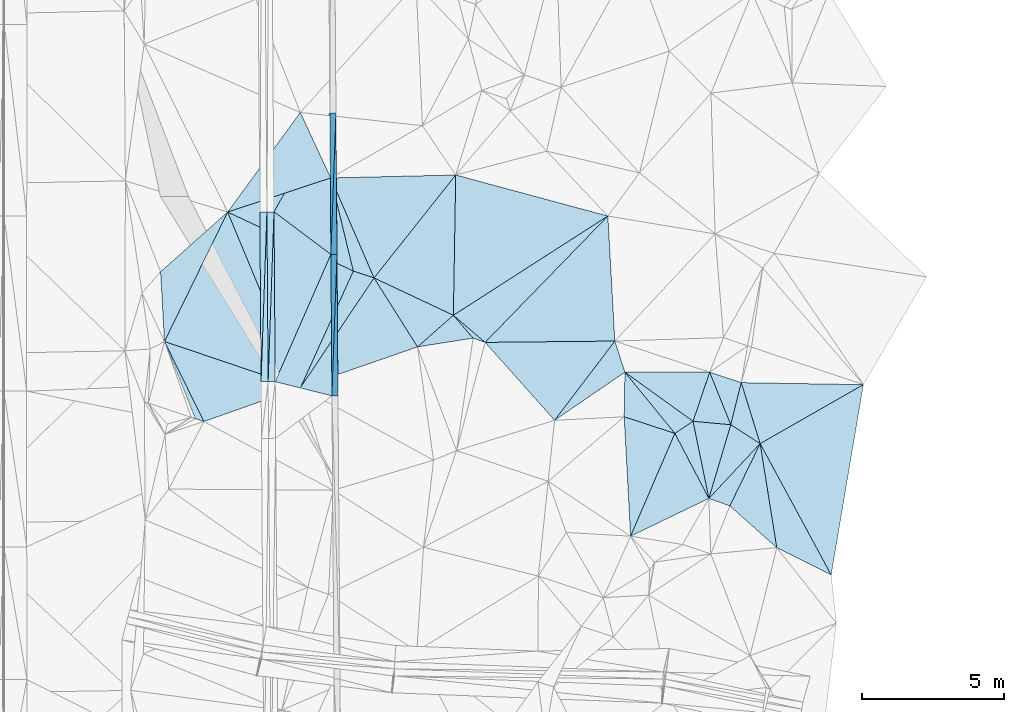
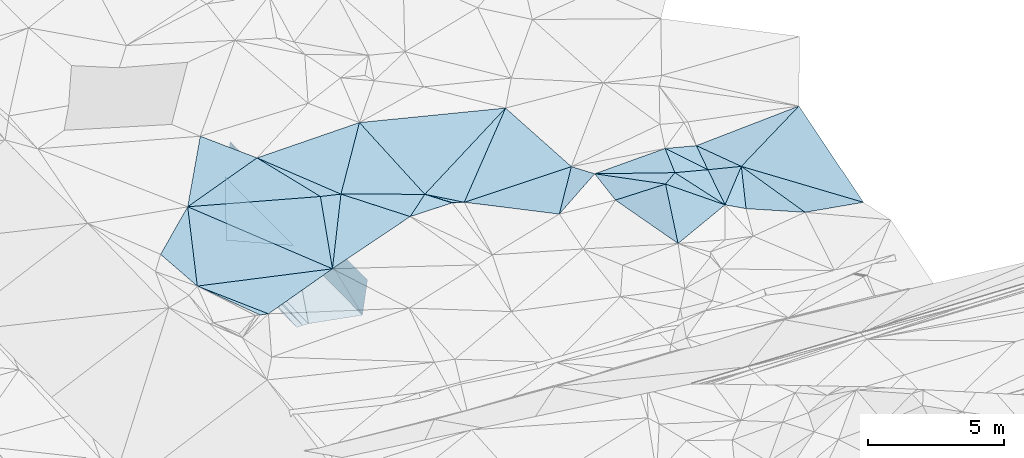
# One storey, part 118 of 275: 47 plates.
"""IFC2X3 building model written with IfcOpenShell, lengths in millimetres."""

from ifc_helpers import new_model, si_unit, frame, origin_with_axes, place, context, subcontext, project, spatial, polyline, outline, extrude, material, type_object, element, save


model = new_model("IFC2X3")

# Units and contexts
model_context = context("Model", 3, precision=1e-05, world=origin_with_axes())
body_context = subcontext(model_context, "Body", "Model", "MODEL_VIEW")
ifc_project = project(units=[si_unit("LENGTHUNIT", "METRE", prefix="MILLI"), si_unit("AREAUNIT", "SQUARE_METRE"), si_unit("VOLUMEUNIT", "CUBIC_METRE"), si_unit("MASSUNIT", "GRAM", prefix="KILO"), si_unit("TIMEUNIT", "SECOND"), si_unit("PLANEANGLEUNIT", "RADIAN"), si_unit("SOLIDANGLEUNIT", "STERADIAN"), si_unit("THERMODYNAMICTEMPERATUREUNIT", "DEGREE_CELSIUS"), si_unit("LUMINOUSINTENSITYUNIT", "LUMEN")], contexts=[model_context])

# Site, building, storey
site_placement = place(None, origin_with_axes())
site = spatial("IfcSite", under=ifc_project, at=site_placement, CompositionType="ELEMENT")
building_placement = place(site_placement, origin_with_axes())
building = spatial("IfcBuilding", under=site, at=building_placement, Name="Undefined", CompositionType="ELEMENT")
storey_placement = place(building_placement, origin_with_axes())
storey = spatial("IfcBuildingStorey", under=building, at=storey_placement, Name="Undefined", CompositionType="ELEMENT", Elevation=0.0)

# Plates
ifc_material = material()
plate_type_1 = type_object("IfcPlateType", PredefinedType="NOTDEFINED")
for number, where, z_axis, x_axis, name in (
    (1, (-45683.2373323279, 92966.7539989016, 44689.9872892128), (0.989902789621391, 0.00962387440535802, -0.141420819334417), (0.00717851400324311, -0.999815950858989, -0.0177913840001465), "00_PR"),
    (2, (-45861.6191404362, 87965.3449309683, 43101.0162901396), (0.989902789621391, 0.00962387440535802, -0.141420819334417), (-0.00717851400874594, 0.999815950858389, 0.0177913840316381), "00_PR"),
):
    element("IfcPlate", number, at=place(storey_placement, frame(where, z_axis=z_axis, x_axis=x_axis)), inside=storey, type_object=plate_type_1, material=ifc_material, Name=name, context=body_context, shape_type="SweptSolid", body=[
        extrude(outline(polyline([(0.0, 0.0), (5000.79150390625, -2.90528987534344e-08), (5027.47802734375, 1514.99377441406), (0.0, 0.0)])), frame((-8.85201319254618e-08, 2.18876761149539e-07, -0.5000001331573), z_axis=(0.0, 0.0, 1.0), x_axis=(1.0, 0.0, 0.0)), (0.0, 0.0, 1.0), 1.0),
    ])
plate_type_2 = type_object("IfcPlateType", PredefinedType="NOTDEFINED")
for number, where, z_axis, x_axis, name in (
    (3, (-45647.3390831942, 87966.8832514009, 44601.0162893921), (0.989898743353492, 0.0100336620146458, -0.14142066162253), (0.00717811400295095, -0.999760220774989, -0.0206875720012088), "00_PR"),
    (4, (-45825.7208917651, 82965.4741815334, 42997.5562900723), (0.989898743353492, 0.0100336620146458, -0.14142066162253), (-0.00717811401574965, 0.99976022077431, 0.0206875720296029), "00_PR"),
):
    element("IfcPlate", number, at=place(storey_placement, frame(where, z_axis=z_axis, x_axis=x_axis)), inside=storey, type_object=plate_type_2, material=ifc_material, Name=name, context=body_context, shape_type="SweptSolid", body=[
        extrude(outline(polyline([(0.0, 0.0), (5001.0703125, -2.76850187219679e-08), (5032.10107421875, 1514.91101074219), (0.0, 0.0)])), frame((-8.85201319254618e-08, 2.18876761149539e-07, -0.5000001331573), z_axis=(0.0, 0.0, 1.0), x_axis=(1.0, 0.0, 0.0)), (0.0, 0.0, 1.0), 1.0),
    ])
plate_type_3 = type_object("IfcPlateType", PredefinedType="NOTDEFINED")
plate_1_placement = place(storey_placement, frame((-48079.9031369125, 83467.4698453673, 43019.8517308433), z_axis=(-0.0500743211191804, 0.0203698148144253, -0.998537747413126), x_axis=(0.0344500070027547, 0.99923227325048, 0.0186563960128271)))
element("IfcPlate", 5, at=plate_1_placement, inside=storey, type_object=plate_type_3, material=ifc_material, Name="00_PR", context=body_context, shape_type="SweptSolid", body=[
    extrude(outline(polyline([(0.0, 0.0), (6006.2509765625, -4.09854692406952e-08), (10.1724472045898, 250.105972290039), (0.0, 0.0)])), frame((-8.85201319254618e-08, 2.18876761149539e-07, -0.5000001331573), z_axis=(0.0, 0.0, 1.0), x_axis=(1.0, 0.0, 0.0)), (0.0, 0.0, 1.0), 1.0),
])
plate_2_placement = place(storey_placement, frame((-48079.9031369125, 83467.4698453673, 43019.8517308433), z_axis=(-0.0500743211191804, 0.0203698148144253, -0.998537747413126), x_axis=(-0.00717807001013827, 0.999758829912239, 0.0207546940097849)))
element("IfcPlate", 6, at=plate_2_placement, inside=storey, type_object=plate_type_3, material=ifc_material, Name="00_PR", context=body_context, shape_type="SweptSolid", body=[
    extrude(outline(polyline([(0.0, 0.0), (6001.29296875, 1.02445483207703e-08), (6001.033203125, 250.311706542969), (0.0, 0.0)])), frame((-8.85201319254618e-08, 2.18876761149539e-07, -0.5000001331573), z_axis=(0.0, 0.0, 1.0), x_axis=(1.0, 0.0, 0.0)), (0.0, 0.0, 1.0), 1.0),
])
for number, where, z_axis, x_axis, name in (
    (7, (-48122.9458806108, 89467.3157739402, 43144.4062080535), (0.0198421780331149, 0.0208935438694051, -0.999584787697111), (0.00717807002162699, -0.999758829911683, -0.0207546940325866), "00_PR"),
    (8, (-48329.8621855433, 83465.6753719548, 43014.851207862), (0.0198421780331149, 0.0208935438694051, -0.999584787697111), (-0.00717807001013827, 0.999758829912239, 0.0207546940097849), "00_PR"),
):
    element("IfcPlate", number, at=place(storey_placement, frame(where, z_axis=z_axis, x_axis=x_axis)), inside=storey, type_object=plate_type_3, material=ifc_material, Name=name, context=body_context, shape_type="SweptSolid", body=[
        extrude(outline(polyline([(0.0, 0.0), (6001.29296875, 1.02445483207703e-08), (6001.396484375, 250.050430297852), (0.0, 0.0)])), frame((-8.85201319254618e-08, 2.18876761149539e-07, -0.5000001331573), z_axis=(0.0, 0.0, 1.0), x_axis=(1.0, 0.0, 0.0)), (0.0, 0.0, 1.0), 1.0),
    ])
plate_type_4 = type_object("IfcPlateType", PredefinedType="NOTDEFINED")
plate_3_placement = place(storey_placement, frame((-45898.0134832116, 92965.2199599248, 43189.5580809568), z_axis=(-0.00227963076145979, 0.0177754340244716, -0.999839405719155), x_axis=(0.00717851400324311, -0.999815950858989, -0.0177913840001465)))
element("IfcPlate", 9, at=plate_3_placement, inside=storey, type_object=plate_type_4, material=ifc_material, Name="00_PR", context=body_context, shape_type="SweptSolid", body=[
    extrude(outline(polyline([(0.0, 0.0), (5000.79150390625, -2.90528987534344e-08), (3482.31640625, 2000.00500488281), (0.0, 0.0)])), frame((-8.85201319254618e-08, 2.18876761149539e-07, -0.5000001331573), z_axis=(0.0, 0.0, 1.0), x_axis=(1.0, 0.0, 0.0)), (0.0, 0.0, 1.0), 1.0),
])
plate_4_placement = place(storey_placement, frame((-45862.1140412533, 87965.3504638584, 43100.5871074765), z_axis=(0.000100272310363569, 0.0206888245440917, -0.999785958335307), x_axis=(0.00717811400295095, -0.999760220774989, -0.0206875720012088)))
element("IfcPlate", 10, at=plate_4_placement, inside=storey, type_object=plate_type_4, material=ifc_material, Name="00_PR", context=body_context, shape_type="SweptSolid", body=[
    extrude(outline(polyline([(0.0, 0.0), (5001.0703125, -2.76850187219679e-08), (4482.8115234375, 1999.99963378906), (0.0, 0.0)])), frame((-8.85201319254618e-08, 2.18876761149539e-07, -0.5000001331573), z_axis=(0.0, 0.0, 1.0), x_axis=(1.0, 0.0, 0.0)), (0.0, 0.0, 1.0), 1.0),
])
plate_5_placement = place(storey_placement, frame((-47872.9627324766, 89469.1100334616, 43131.9061082618), z_axis=(-5.06882224549782e-05, 0.0207548664900474, -0.999784593273813), x_axis=(0.800773641961817, -0.598837224948012, -0.0124720630118285)))
element("IfcPlate", 11, at=plate_5_placement, inside=storey, type_object=plate_type_4, material=ifc_material, Name="00_PR", context=body_context, shape_type="SweptSolid", body=[
    extrude(outline(polyline([(0.0, 0.0), (2511.13232421875, 3.71801434084773e-09), (3628.98046875, 4779.75048828125), (0.0, 0.0)])), frame((-8.85201319254618e-08, 2.18876761149539e-07, -0.5000001331573), z_axis=(0.0, 0.0, 1.0), x_axis=(1.0, 0.0, 0.0)), (0.0, 0.0, 1.0), 1.0),
])
plate_type_5 = type_object("IfcPlateType", PredefinedType="NOTDEFINED")
plate_6_placement = place(storey_placement, frame((-45069.3131982362, 87377.9734556532, 45389.5001155122), z_axis=(0.00706609497051216, 0.0210894659351489, -0.999752621766224), x_axis=(0.948192909023164, -0.31769514833908, 1.36898628105037e-10)))
element("IfcPlate", 12, at=plate_6_placement, inside=storey, type_object=plate_type_5, material=ifc_material, Name="00", context=body_context, shape_type="SweptSolid", body=[
    extrude(outline(polyline([(0.0, 0.0), (771.556884765625, -1.94995664060116e-09), (-461.015930175781, 4496.0498046875), (0.0, 0.0)])), frame((-8.85201319254618e-08, 2.18876761149539e-07, -0.5000001331573), z_axis=(0.0, 0.0, 1.0), x_axis=(1.0, 0.0, 0.0)), (0.0, 0.0, 1.0), 1.0),
])
plate_type_6 = type_object("IfcPlateType", PredefinedType="NOTDEFINED")
plate_7_placement = place(storey_placement, frame((-37959.0404684161, 82102.4163246774, 45309.502815184), z_axis=(-0.00542668028163946, -0.105954084567651, -0.99435621539997), x_axis=(-0.663259744439591, 0.744549252573234, -0.0757160610344114)))
element("IfcPlate", 13, at=plate_7_placement, inside=storey, type_object=plate_type_6, material=ifc_material, Name="00", context=body_context, shape_type="SweptSolid", body=[
    extrude(outline(polyline([(0.0, 0.0), (3698.02661132813, 1.55523594003171e-08), (695.884704589844, 3462.40454101563), (0.0, 0.0)])), frame((-8.85201319254618e-08, 2.18876761149539e-07, -0.5000001331573), z_axis=(0.0, 0.0, 1.0), x_axis=(1.0, 0.0, 0.0)), (0.0, 0.0, 1.0), 1.0),
])
plate_type_7 = type_object("IfcPlateType", PredefinedType="NOTDEFINED")
plate_8_placement = place(storey_placement, frame((-32479.007107718, 83803.5718765029, 45309.5097408913), z_axis=(-0.194021096222563, -0.030273157857917, -0.980530137289979), x_axis=(0.371728776040568, -0.927253620632982, -0.0449270529459386)))
element("IfcPlate", 14, at=plate_8_placement, inside=storey, type_object=plate_type_7, material=ifc_material, Name="00", context=body_context, shape_type="SweptSolid", body=[
    extrude(outline(polyline([(0.0, 0.0), (2003.24731445313, -1.27402017824352e-08), (1383.50366210938, 1214.4619140625), (0.0, 0.0)])), frame((-8.85201319254618e-08, 2.18876761149539e-07, -0.5000001331573), z_axis=(0.0, 0.0, 1.0), x_axis=(1.0, 0.0, 0.0)), (0.0, 0.0, 1.0), 1.0),
])
plate_type_8 = type_object("IfcPlateType", PredefinedType="NOTDEFINED")
plate_9_placement = place(storey_placement, frame((-35829.3912940867, 84902.594573461, 44999.5089668839), z_axis=(0.080892518904308, -0.170241806279899, -0.982076436831611), x_axis=(0.301823274072309, -0.934860647811207, 0.186917843991104)))
element("IfcPlate", 15, at=plate_9_placement, inside=storey, type_object=plate_type_8, material=ifc_material, Name="00", context=body_context, shape_type="SweptSolid", body=[
    extrude(outline(polyline([(0.0, 0.0), (1176.98767089844, 2.25554686039686e-10), (2032.98645019531, 2887.8134765625), (0.0, 0.0)])), frame((-8.85201319254618e-08, 2.18876761149539e-07, -0.5000001331573), z_axis=(0.0, 0.0, 1.0), x_axis=(1.0, 0.0, 0.0)), (0.0, 0.0, 1.0), 1.0),
])
plate_type_9 = type_object("IfcPlateType", PredefinedType="NOTDEFINED")
plate_10_placement = place(storey_placement, frame((-31734.1971798722, 81946.0032001781, 45219.5066586934), z_axis=(0.0964550703391548, -0.130885011541234, -0.986694245022094), x_axis=(0.831550725592776, -0.534203576559555, 0.152151009057148)))
element("IfcPlate", 16, at=plate_10_placement, inside=storey, type_object=plate_type_9, material=ifc_material, Name="00", context=body_context, shape_type="SweptSolid", body=[
    extrude(outline(polyline([(0.0, 0.0), (1248.75939941406, -2.51020537689328e-09), (790.064147949219, 2613.65625), (0.0, 0.0)])), frame((-8.85201319254618e-08, 2.18876761149539e-07, -0.5000001331573), z_axis=(0.0, 0.0, 1.0), x_axis=(1.0, 0.0, 0.0)), (0.0, 0.0, 1.0), 1.0),
])
plate_type_10 = type_object("IfcPlateType", PredefinedType="NOTDEFINED")
plate_11_placement = place(storey_placement, frame((-32507.0603143822, 79341.1652521589, 45489.5101011329), z_axis=(-0.195102063017076, -0.0436833121646322, -0.979809651536873), x_axis=(-0.201272626133684, 0.979528672924914, -0.00359289398764216)))
element("IfcPlate", 17, at=plate_11_placement, inside=storey, type_object=plate_type_10, material=ifc_material, Name="00", context=body_context, shape_type="SweptSolid", body=[
    extrude(outline(polyline([(0.0, 0.0), (2783.271484375, -2.91038304567337e-09), (2396.99951171875, 1307.5908203125), (0.0, 0.0)])), frame((-8.85201319254618e-08, 2.18876761149539e-07, -0.5000001331573), z_axis=(0.0, 0.0, 1.0), x_axis=(1.0, 0.0, 0.0)), (0.0, 0.0, 1.0), 1.0),
])
plate_type_11 = type_object("IfcPlateType", PredefinedType="NOTDEFINED")
plate_12_placement = place(storey_placement, frame((-49510.4156340631, 89460.0204792745, 45219.5000540307), z_axis=(0.0149171128117454, -0.00509312745644573, -0.999875762181519), x_axis=(0.383781072661369, -0.923365216938025, 0.0104290179730582)))
element("IfcPlate", 18, at=plate_12_placement, inside=storey, type_object=plate_type_11, material=ifc_material, Name="00", context=body_context, shape_type="SweptSolid", body=[
    extrude(outline(polyline([(0.0, 0.0), (6712.04150390625, -3.09519236907363e-08), (3365.83154296875, 3815.98999023438), (0.0, 0.0)])), frame((-8.85201319254618e-08, 2.18876761149539e-07, -0.5000001331573), z_axis=(0.0, 0.0, 1.0), x_axis=(1.0, 0.0, 0.0)), (0.0, 0.0, 1.0), 1.0),
])
plate_type_12 = type_object("IfcPlateType", PredefinedType="NOTDEFINED")
plate_13_placement = place(storey_placement, frame((-35499.4782809632, 82227.6693787612, 44999.5244804639), z_axis=(0.281136504555404, 0.128325812423264, -0.951049289822709), x_axis=(0.0159907927948712, 0.99025528956161, 0.138342892990725)))
element("IfcPlate", 19, at=plate_13_placement, inside=storey, type_object=plate_type_12, material=ifc_material, Name="00", context=body_context, shape_type="SweptSolid", body=[
    extrude(outline(polyline([(0.0, 0.0), (1590.25158691406, 3.66708263754845e-09), (-489.733825683594, 1873.56896972656), (0.0, 0.0)])), frame((-8.85201319254618e-08, 2.18876761149539e-07, -0.5000001331573), z_axis=(0.0, 0.0, 1.0), x_axis=(1.0, 0.0, 0.0)), (0.0, 0.0, 1.0), 1.0),
])
plate_type_13 = type_object("IfcPlateType", PredefinedType="NOTDEFINED")
plate_14_placement = place(storey_placement, frame((-51741.9884825936, 84887.2114247014, 45209.5000925709), z_axis=(0.0189288990313736, -0.0070510934098167, -0.99979596861719), x_axis=(-0.056036672613361, 0.998395836590678, -0.00810214791416807)))
element("IfcPlate", 20, at=plate_14_placement, inside=storey, type_object=plate_type_13, material=ifc_material, Name="00", context=body_context, shape_type="SweptSolid", body=[
    extrude(outline(polyline([(0.0, 0.0), (2468.48120117188, -1.78988557308912e-09), (4440.34130859375, 2484.7470703125), (0.0, 0.0)])), frame((-8.85201319254618e-08, 2.18876761149539e-07, -0.5000001331573), z_axis=(0.0, 0.0, 1.0), x_axis=(1.0, 0.0, 0.0)), (0.0, 0.0, 1.0), 1.0),
])
plate_type_14 = type_object("IfcPlateType", PredefinedType="NOTDEFINED")
plate_15_placement = place(storey_placement, frame((-41534.985015347, 85813.5055388297, 45199.5055283287), z_axis=(-0.139167559526725, 0.0515075948223284, -0.988928388737523), x_axis=(0.647270419543151, -0.751057556634857, -0.13020580096951)))
element("IfcPlate", 21, at=plate_15_placement, inside=storey, type_object=plate_type_14, material=ifc_material, Name="00", context=body_context, shape_type="SweptSolid", body=[
    extrude(outline(polyline([(0.0, 0.0), (1075.22094726563, 1.54614099301398e-09), (3.99917817115784, 1693.09887695313), (0.0, 0.0)])), frame((-8.85201319254618e-08, 2.18876761149539e-07, -0.5000001331573), z_axis=(0.0, 0.0, 1.0), x_axis=(1.0, 0.0, 0.0)), (0.0, 0.0, 1.0), 1.0),
])
plate_type_15 = type_object("IfcPlateType", PredefinedType="NOTDEFINED")
plate_16_placement = place(storey_placement, frame((-30695.9725358323, 81279.0826604952, 45409.5300178736), z_axis=(-0.267800766856373, 0.211489577245417, -0.93997601458106), x_axis=(-0.436350901048086, -0.896443284541261, -0.0773778311624195)))
element("IfcPlate", 22, at=plate_16_placement, inside=storey, type_object=plate_type_15, material=ifc_material, Name="00", context=body_context, shape_type="SweptSolid", body=[
    extrude(outline(polyline([(0.0, 0.0), (2455.48364257813, -1.29366526380181e-08), (2521.21411132813, 827.6953125), (0.0, 0.0)])), frame((-8.85201319254618e-08, 2.18876761149539e-07, -0.5000001331573), z_axis=(0.0, 0.0, 1.0), x_axis=(1.0, 0.0, 0.0)), (0.0, 0.0, 1.0), 1.0),
])
plate_type_16 = type_object("IfcPlateType", PredefinedType="NOTDEFINED")
plate_17_placement = place(storey_placement, frame((-40411.7964613095, 84855.9120419585, 45029.5064584402), z_axis=(-0.0131881662296389, 0.159755708752198, -0.987068480801906), x_axis=(-0.941389601389961, 0.330778724460133, 0.0661139458766262)))
element("IfcPlate", 23, at=plate_17_placement, inside=storey, type_object=plate_type_16, material=ifc_material, Name="00", context=body_context, shape_type="SweptSolid", body=[
    extrude(outline(polyline([(0.0, 0.0), (453.762054443359, -2.29556462727487e-09), (1385.3076171875, 536.957153320313), (0.0, 0.0)])), frame((-8.85201319254618e-08, 2.18876761149539e-07, -0.5000001331573), z_axis=(0.0, 0.0, 1.0), x_axis=(1.0, 0.0, 0.0)), (0.0, 0.0, 1.0), 1.0),
])
plate_type_17 = type_object("IfcPlateType", PredefinedType="NOTDEFINED")
plate_18_placement = place(storey_placement, frame((-36076.6303756705, 89319.933680033, 45039.5000354299), z_axis=(-0.00663523232918316, 0.00868355123193243, -0.999940283031912), x_axis=(0.0558716591705194, -0.998397025213092, -0.00904089305218204)))
element("IfcPlate", 24, at=plate_18_placement, inside=storey, type_object=plate_type_17, material=ifc_material, Name="00", context=body_context, shape_type="SweptSolid", body=[
    extrude(outline(polyline([(0.0, 0.0), (4424.341796875, 1.10994733404368e-08), (4214.81884765625, 4577.9033203125), (0.0, 0.0)])), frame((-8.85201319254618e-08, 2.18876761149539e-07, -0.5000001331573), z_axis=(0.0, 0.0, 1.0), x_axis=(1.0, 0.0, 0.0)), (0.0, 0.0, 1.0), 1.0),
])
plate_type_18 = type_object("IfcPlateType", PredefinedType="NOTDEFINED")
plate_19_placement = place(storey_placement, frame((-31734.2567949943, 81946.0882787953, 45219.5005214637), z_axis=(-0.0227761751673232, 0.0392709955451937, -0.998968985881762), x_axis=(-0.371728776044028, 0.927253620631453, 0.044927052948877)))
element("IfcPlate", 25, at=plate_19_placement, inside=storey, type_object=plate_type_18, material=ifc_material, Name="00", context=body_context, shape_type="SweptSolid", body=[
    extrude(outline(polyline([(0.0, 0.0), (2003.24731445313, -1.27402017824352e-08), (1243.13159179688, 897.119812011719), (0.0, 0.0)])), frame((-8.85201319254618e-08, 2.18876761149539e-07, -0.5000001331573), z_axis=(0.0, 0.0, 1.0), x_axis=(1.0, 0.0, 0.0)), (0.0, 0.0, 1.0), 1.0),
])
plate_type_19 = type_object("IfcPlateType", PredefinedType="NOTDEFINED")
plate_20_placement = place(storey_placement, frame((-28184.8235706216, 76637.9508991514, 45729.5013580698), z_axis=(0.0654896818174917, -0.0333314161094109, -0.997296404423271), x_axis=(-0.47498590190887, 0.877909013475588, -0.060532281025393)))
element("IfcPlate", 26, at=plate_20_placement, inside=storey, type_object=plate_type_19, material=ifc_material, Name="00", context=body_context, shape_type="SweptSolid", body=[
    extrude(outline(polyline([(0.0, 0.0), (5286.435546875, -2.04508978640661e-08), (5371.8994140625, 4204.6279296875), (0.0, 0.0)])), frame((-8.85201319254618e-08, 2.18876761149539e-07, -0.5000001331573), z_axis=(0.0, 0.0, 1.0), x_axis=(1.0, 0.0, 0.0)), (0.0, 0.0, 1.0), 1.0),
])
plate_type_20 = type_object("IfcPlateType", PredefinedType="NOTDEFINED")
plate_21_placement = place(storey_placement, frame((-33067.121228654, 82067.4592223667, 45479.5019323227), z_axis=(0.0757875477335134, -0.0441386339537898, -0.996146589915979), x_axis=(-0.832709603420894, -0.552343305842593, -0.0388791571602632)))
element("IfcPlate", 27, at=plate_21_placement, inside=storey, type_object=plate_type_20, material=ifc_material, Name="00", context=body_context, shape_type="SweptSolid", body=[
    extrude(outline(polyline([(0.0, 0.0), (771.621643066406, 7.13043846189976e-10), (1056.21704101563, 2784.888671875), (0.0, 0.0)])), frame((-8.85201319254618e-08, 2.18876761149539e-07, -0.5000001331573), z_axis=(0.0, 0.0, 1.0), x_axis=(1.0, 0.0, 0.0)), (0.0, 0.0, 1.0), 1.0),
])
plate_type_21 = type_object("IfcPlateType", PredefinedType="NOTDEFINED")
plate_22_placement = place(storey_placement, frame((-32478.8951458552, 83803.5332952813, 45309.5031248418), z_axis=(0.0299038375530636, -0.107441824182214, -0.993761548318307), x_axis=(-0.319540146810321, -0.943062301950931, 0.092344946886387)))
element("IfcPlate", 28, at=plate_22_placement, inside=storey, type_object=plate_type_21, material=ifc_material, Name="00", context=body_context, shape_type="SweptSolid", body=[
    extrude(outline(polyline([(0.0, 0.0), (1840.92370605469, -7.9890014603734e-09), (949.957885742188, 2842.0732421875), (0.0, 0.0)])), frame((-8.85201319254618e-08, 2.18876761149539e-07, -0.5000001331573), z_axis=(0.0, 0.0, 1.0), x_axis=(1.0, 0.0, 0.0)), (0.0, 0.0, 1.0), 1.0),
])
plate_type_22 = type_object("IfcPlateType", PredefinedType="NOTDEFINED")
plate_23_placement = place(storey_placement, frame((-32506.9411709979, 79341.1897008722, 45489.5004788604), z_axis=(0.0431898333453875, 0.00521009578161588, -0.999053298476885), x_axis=(-0.463323614112765, 0.886055184823519, -0.0154090250452651)))
element("IfcPlate", 29, at=plate_23_placement, inside=storey, type_object=plate_type_22, material=ifc_material, Name="00", context=body_context, shape_type="SweptSolid", body=[
    extrude(outline(polyline([(0.0, 0.0), (2595.88134765625, 1.35769369080663e-08), (2675.353515625, 767.518188476563), (0.0, 0.0)])), frame((-8.85201319254618e-08, 2.18876761149539e-07, -0.5000001331573), z_axis=(0.0, 0.0, 1.0), x_axis=(1.0, 0.0, 0.0)), (0.0, 0.0, 1.0), 1.0),
])
plate_type_23 = type_object("IfcPlateType", PredefinedType="NOTDEFINED")
plate_24_placement = place(storey_placement, frame((-33709.6983225532, 81641.271265789, 45449.5001106321), z_axis=(-0.00485471230257463, -0.019925493793915, -0.999789681115747), x_axis=(0.463323614101443, -0.886055184829428, 0.0154090250458884)))
element("IfcPlate", 30, at=plate_24_placement, inside=storey, type_object=plate_type_23, material=ifc_material, Name="00", context=body_context, shape_type="SweptSolid", body=[
    extrude(outline(polyline([(0.0, 0.0), (2595.88134765625, 1.35769369080663e-08), (2495.22192382813, 3070.23901367188), (0.0, 0.0)])), frame((-8.85201319254618e-08, 2.18876761149539e-07, -0.5000001331573), z_axis=(0.0, 0.0, 1.0), x_axis=(1.0, 0.0, 0.0)), (0.0, 0.0, 1.0), 1.0),
])
plate_type_24 = type_object("IfcPlateType", PredefinedType="NOTDEFINED")
plate_25_placement = place(storey_placement, frame((-30695.8032028847, 81278.9555147021, 45409.5017222141), z_axis=(0.0708625195909075, -0.0428015546877942, -0.996567373654956), x_axis=(-0.295626084213284, 0.953292030172093, -0.0619638890249046)))
element("IfcPlate", 31, at=plate_25_placement, inside=storey, type_object=plate_type_24, material=ifc_material, Name="00", context=body_context, shape_type="SweptSolid", body=[
    extrude(outline(polyline([(0.0, 0.0), (2259.38037109375, 1.34364199766424e-08), (896.794494628906, 4108.76611328125), (0.0, 0.0)])), frame((-8.85201319254618e-08, 2.18876761149539e-07, -0.5000001331573), z_axis=(0.0, 0.0, 1.0), x_axis=(1.0, 0.0, 0.0)), (0.0, 0.0, 1.0), 1.0),
])
plate_type_25 = type_object("IfcPlateType", PredefinedType="NOTDEFINED")
plate_26_placement = place(storey_placement, frame((-28184.7539898247, 76637.9892145977, 45729.51106737), z_axis=(0.204647924119921, 0.0432980173209078, -0.977877553096238), x_axis=(-0.88177130212365, 0.441887413905312, -0.164969343161807)))
element("IfcPlate", 32, at=plate_26_placement, inside=storey, type_object=plate_type_25, material=ifc_material, Name="00", context=body_context, shape_type="SweptSolid", body=[
    extrude(outline(polyline([(0.0, 0.0), (2182.2236328125, -7.50151230022311e-09), (4317.7060546875, 3050.21557617188), (0.0, 0.0)])), frame((-8.85201319254618e-08, 2.18876761149539e-07, -0.5000001331573), z_axis=(0.0, 0.0, 1.0), x_axis=(1.0, 0.0, 0.0)), (0.0, 0.0, 1.0), 1.0),
])
plate_type_26 = type_object("IfcPlateType", PredefinedType="NOTDEFINED")
plate_27_placement = place(storey_placement, frame((-30109.0205519751, 77602.2793696157, 45369.5035904297), z_axis=(0.115876640375076, 0.0292938498480841, -0.992831543906852), x_axis=(-0.745363864892661, 0.663239482727181, -0.0674247540896963)))
element("IfcPlate", 33, at=plate_27_placement, inside=storey, type_object=plate_type_26, material=ifc_material, Name="00", context=body_context, shape_type="SweptSolid", body=[
    extrude(outline(polyline([(0.0, 0.0), (2224.7021484375, 7.66885932534933e-09), (2873.19360351563, 2368.30297851563), (0.0, 0.0)])), frame((-8.85201319254618e-08, 2.18876761149539e-07, -0.5000001331573), z_axis=(0.0, 0.0, 1.0), x_axis=(1.0, 0.0, 0.0)), (0.0, 0.0, 1.0), 1.0),
])
plate_type_27 = type_object("IfcPlateType", PredefinedType="NOTDEFINED")
plate_28_placement = place(storey_placement, frame((-44337.7342898945, 87132.8448681936, 45389.5000006569), z_axis=(-0.00461629474015407, 0.00366223477918768, -0.999982638778941), x_axis=(-0.397199369568947, 0.917717645675166, 0.0051945770241995)))
element("IfcPlate", 34, at=plate_28_placement, inside=storey, type_object=plate_type_27, material=ifc_material, Name="00", context=body_context, shape_type="SweptSolid", body=[
    extrude(outline(polyline([(0.0, 0.0), (3850.1689453125, 8.20364220999181e-10), (2191.92993164063, 4093.06030273438), (0.0, 0.0)])), frame((-8.85201319254618e-08, 2.18876761149539e-07, -0.5000001331573), z_axis=(0.0, 0.0, 1.0), x_axis=(1.0, 0.0, 0.0)), (0.0, 0.0, 1.0), 1.0),
])
plate_type_28 = type_object("IfcPlateType", PredefinedType="NOTDEFINED")
plate_29_placement = place(storey_placement, frame((-35274.2684730766, 78008.3361101742, 45529.5140835068), z_axis=(0.207971240720197, -0.11097316319244, -0.971819386555118), x_axis=(-0.0528954556219835, 0.99081346323804, -0.12446184893687)))
element("IfcPlate", 35, at=plate_29_placement, inside=storey, type_object=plate_type_28, material=ifc_material, Name="00", context=body_context, shape_type="SweptSolid", body=[
    extrude(outline(polyline([(0.0, 0.0), (4258.3330078125, 1.07756932266057e-08), (3526.70874023438, 1792.99353027344), (0.0, 0.0)])), frame((-8.85201319254618e-08, 2.18876761149539e-07, -0.5000001331573), z_axis=(0.0, 0.0, 1.0), x_axis=(1.0, 0.0, 0.0)), (0.0, 0.0, 1.0), 1.0),
])
plate_type_29 = type_object("IfcPlateType", PredefinedType="NOTDEFINED")
plate_30_placement = place(storey_placement, frame((-45867.0155030082, 90666.2142192945, 45409.5000043242), z_axis=(0.00221812543272941, 0.0066202153430491, -0.999975626037143), x_axis=(0.397199369567699, -0.917717645675689, -0.00519457702741442)))
element("IfcPlate", 36, at=plate_30_placement, inside=storey, type_object=plate_type_29, material=ifc_material, Name="00", context=body_context, shape_type="SweptSolid", body=[
    extrude(outline(polyline([(0.0, 0.0), (3850.1689453125, 8.20364220999181e-10), (3334.63305664063, 574.040771484375), (0.0, 0.0)])), frame((-8.85201319254618e-08, 2.18876761149539e-07, -0.5000001331573), z_axis=(0.0, 0.0, 1.0), x_axis=(1.0, 0.0, 0.0)), (0.0, 0.0, 1.0), 1.0),
])
plate_type_30 = type_object("IfcPlateType", PredefinedType="NOTDEFINED")
plate_31_placement = place(storey_placement, frame((-46943.7974804301, 92978.2431382123, 45359.5006523778), z_axis=(0.0513176346445313, 0.00230324649047522, -0.998679726153532), x_axis=(0.422114811705173, -0.906330466014682, 0.0196003089954215)))
element("IfcPlate", 37, at=plate_31_placement, inside=storey, type_object=plate_type_30, material=ifc_material, Name="00", context=body_context, shape_type="SweptSolid", body=[
    extrude(outline(polyline([(0.0, 0.0), (2550.98022460938, 1.01476871350314e-08), (2102.52514648438, 3816.31860351563), (0.0, 0.0)])), frame((-8.85201319254618e-08, 2.18876761149539e-07, -0.5000001331573), z_axis=(0.0, 0.0, 1.0), x_axis=(1.0, 0.0, 0.0)), (0.0, 0.0, 1.0), 1.0),
])
plate_32_placement = place(storey_placement, frame((-51741.9865369902, 84887.2241024804, 45209.5002047076), z_axis=(0.0228195817250194, 0.0183031695965164, -0.999572038760897), x_axis=(0.947236194155123, -0.320148613386544, 0.0157625451368639)))
element("IfcPlate", 38, at=plate_32_placement, inside=storey, type_object=plate_type_30, material=ifc_material, Name="00", context=body_context, shape_type="SweptSolid", body=[
    extrude(outline(polyline([(0.0, 0.0), (5075.32275390625, 7.15226633474231e-09), (2224.31176757813, 2234.33154296875), (0.0, 0.0)])), frame((-8.85201319254618e-08, 2.18876761149539e-07, -0.5000001331573), z_axis=(0.0, 0.0, 1.0), x_axis=(1.0, 0.0, 0.0)), (0.0, 0.0, 1.0), 1.0),
])
plate_type_31 = type_object("IfcPlateType", PredefinedType="NOTDEFINED")
plate_33_placement = place(storey_placement, frame((-44337.7704450801, 87132.8331022973, 45389.5015727708), z_axis=(-0.0769288055148935, -0.0198717116940609, -0.99683853956215), x_axis=(0.903073108161457, -0.425101483364506, -0.0612183808745501)))
element("IfcPlate", 39, at=plate_33_placement, inside=storey, type_object=plate_type_31, material=ifc_material, Name="00", context=body_context, shape_type="SweptSolid", body=[
    extrude(outline(polyline([(0.0, 0.0), (3103.64306640625, -4.62023308500648e-09), (2427.759765625, 1552.34729003906), (0.0, 0.0)])), frame((-8.85201319254618e-08, 2.18876761149539e-07, -0.5000001331573), z_axis=(0.0, 0.0, 1.0), x_axis=(1.0, 0.0, 0.0)), (0.0, 0.0, 1.0), 1.0),
])
plate_type_32 = type_object("IfcPlateType", PredefinedType="NOTDEFINED")
plate_34_placement = place(storey_placement, frame((-41452.103353595, 90770.266221245, 45389.5009824792), z_axis=(-0.0492593409380892, 0.039078802162258, -0.998021224499714), x_axis=(-0.0166972513406779, -0.999126852525693, -0.0382979680892975)))
element("IfcPlate", 40, at=plate_34_placement, inside=storey, type_object=plate_type_32, material=ifc_material, Name="00", context=body_context, shape_type="SweptSolid", body=[
    extrude(outline(polyline([(0.0, 0.0), (4961.0986328125, -3.35712684318423e-08), (3682.41015625, 2827.99487304688), (0.0, 0.0)])), frame((-8.85201319254618e-08, 2.18876761149539e-07, -0.5000001331573), z_axis=(0.0, 0.0, 1.0), x_axis=(1.0, 0.0, 0.0)), (0.0, 0.0, 1.0), 1.0),
])
plate_type_33 = type_object("IfcPlateType", PredefinedType="NOTDEFINED")
plate_35_placement = place(storey_placement, frame((-49510.402625354, 89460.025886166, 45219.5004184951), z_axis=(0.0409311425339184, 0.00572740963160736, -0.999145554136023), x_axis=(0.904892759571263, -0.424227876572517, 0.0346381641297208)))
element("IfcPlate", 41, at=plate_35_placement, inside=storey, type_object=plate_type_33, material=ifc_material, Name="00", context=body_context, shape_type="SweptSolid", body=[
    extrude(outline(polyline([(0.0, 0.0), (4907.88134765625, 9.65519575402141e-09), (4962.60986328125, 4519.29248046875), (0.0, 0.0)])), frame((-8.85201319254618e-08, 2.18876761149539e-07, -0.5000001331573), z_axis=(0.0, 0.0, 1.0), x_axis=(1.0, 0.0, 0.0)), (0.0, 0.0, 1.0), 1.0),
])
plate_type_34 = type_object("IfcPlateType", PredefinedType="NOTDEFINED")
plate_36_placement = place(storey_placement, frame((-44337.7330894568, 87132.8566957358, 45389.5001799041), z_axis=(-0.00221943690195143, 0.0273158837059994, -0.999624387756321), x_axis=(0.533209837586521, -0.845634186748138, -0.0242917949886713)))
element("IfcPlate", 42, at=plate_36_placement, inside=storey, type_object=plate_type_34, material=ifc_material, Name="00", context=body_context, shape_type="SweptSolid", body=[
    extrude(outline(polyline([(0.0, 0.0), (2881.63159179688, -1.09048414742574e-08), (1890.83862304688, 4261.27099609375), (0.0, 0.0)])), frame((-8.85201319254618e-08, 2.18876761149539e-07, -0.5000001331573), z_axis=(0.0, 0.0, 1.0), x_axis=(1.0, 0.0, 0.0)), (0.0, 0.0, 1.0), 1.0),
])
plate_type_35 = type_object("IfcPlateType", PredefinedType="NOTDEFINED")
plate_37_placement = place(storey_placement, frame((-45866.9934366259, 90666.2195715541, 45409.5006050451), z_axis=(0.0463513981023542, 0.0173192551481553, -0.998775045390638), x_axis=(0.235749108682497, -0.971795977106396, -0.00591072205686715)))
element("IfcPlate", 43, at=plate_37_placement, inside=storey, type_object=plate_type_35, material=ifc_material, Name="00", context=body_context, shape_type="SweptSolid", body=[
    extrude(outline(polyline([(0.0, 0.0), (3383.68139648438, -6.62112142890692e-09), (314.361755371094, 3829.69677734375), (0.0, 0.0)])), frame((-8.85201319254618e-08, 2.18876761149539e-07, -0.5000001331573), z_axis=(0.0, 0.0, 1.0), x_axis=(1.0, 0.0, 0.0)), (0.0, 0.0, 1.0), 1.0),
])
plate_type_36 = type_object("IfcPlateType", PredefinedType="NOTDEFINED")
plate_38_placement = place(storey_placement, frame((-31363.6836726001, 83432.821268718, 45269.5076177281), z_axis=(0.173658908667848, -0.0101553908506644, -0.984753497824183), x_axis=(0.295626084651789, -0.953292030040187, 0.0619638889621433)))
element("IfcPlate", 44, at=plate_38_placement, inside=storey, type_object=plate_type_36, material=ifc_material, Name="00", context=body_context, shape_type="SweptSolid", body=[
    extrude(outline(polyline([(0.0, 0.0), (2259.38037109375, 1.34364199766424e-08), (1304.69396972656, 804.968139648438), (0.0, 0.0)])), frame((-8.85201319254618e-08, 2.18876761149539e-07, -0.5000001331573), z_axis=(0.0, 0.0, 1.0), x_axis=(1.0, 0.0, 0.0)), (0.0, 0.0, 1.0), 1.0),
])
plate_type_37 = type_object("IfcPlateType", PredefinedType="NOTDEFINED")
plate_39_placement = place(storey_placement, frame((-51741.9762705408, 84887.2291546494, 45209.5006629322), z_axis=(0.0433522223759415, 0.0284059016406556, -0.998655941536948), x_axis=(0.441704397419888, -0.897138218468371, -0.00634367900596221)))
element("IfcPlate", 45, at=plate_39_placement, inside=storey, type_object=plate_type_37, material=ifc_material, Name="00", context=body_context, shape_type="SweptSolid", body=[
    extrude(outline(polyline([(0.0, 0.0), (3152.74487304688, 6.00630301050842e-09), (2933.50732421875, 221.438262939453), (0.0, 0.0)])), frame((-8.85201319254618e-08, 2.18876761149539e-07, -0.5000001331573), z_axis=(0.0, 0.0, 1.0), x_axis=(1.0, 0.0, 0.0)), (0.0, 0.0, 1.0), 1.0),
])
plate_type_38 = type_object("IfcPlateType", PredefinedType="NOTDEFINED")
plate_40_placement = place(storey_placement, frame((-41534.942668632, 85813.499378376, 45199.5011187025), z_axis=(-0.0544003920271672, 0.0391543695503509, -0.997751237880668), x_axis=(0.0166972513208346, 0.999126852528923, 0.0382979680136834)))
element("IfcPlate", 46, at=plate_40_placement, inside=storey, type_object=plate_type_38, material=ifc_material, Name="00", context=body_context, shape_type="SweptSolid", body=[
    extrude(outline(polyline([(0.0, 0.0), (4961.0986328125, -3.35712684318423e-08), (3588.39868164063, 5407.1337890625), (0.0, 0.0)])), frame((-8.85201319254618e-08, 2.18876761149539e-07, -0.5000001331573), z_axis=(0.0, 0.0, 1.0), x_axis=(1.0, 0.0, 0.0)), (0.0, 0.0, 1.0), 1.0),
])
plate_type_39 = type_object("IfcPlateType", PredefinedType="NOTDEFINED")
plate_41_placement = place(storey_placement, frame((-36076.6677784076, 89319.9699575164, 45039.5032993779), z_axis=(-0.0812159428144353, 0.0810955108951838, -0.993391910952274), x_axis=(-0.696669944636, -0.717389995556028, -0.00160702115551375)))
element("IfcPlate", 47, at=plate_41_placement, inside=storey, type_object=plate_type_39, material=ifc_material, Name="00", context=body_context, shape_type="SweptSolid", body=[
    extrude(outline(polyline([(0.0, 0.0), (6222.6923828125, 1.14814611151814e-08), (6317.8603515625, 1482.68103027344), (0.0, 0.0)])), frame((-8.85201319254618e-08, 2.18876761149539e-07, -0.5000001331573), z_axis=(0.0, 0.0, 1.0), x_axis=(1.0, 0.0, 0.0)), (0.0, 0.0, 1.0), 1.0),
])

save(model, "model.ifc")
